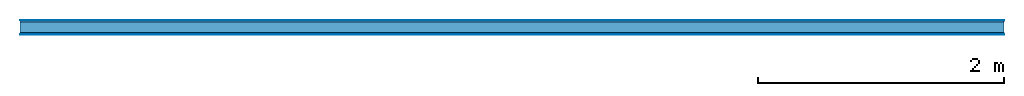
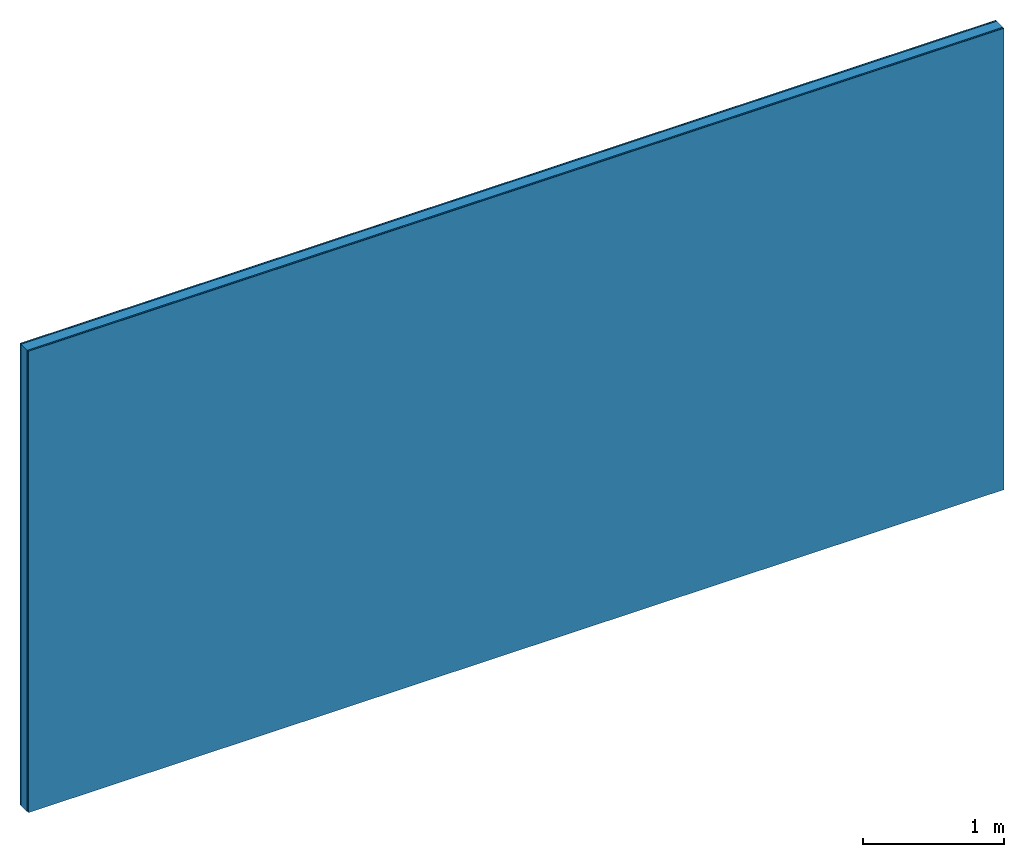
# One storey: 4 plates, 1 member, 1 element without a shape of its own.
"""IFC4 building model written with IfcOpenShell, lengths in metres."""

from ifc_helpers import new_model, si_unit, derived_unit, direction, frame, frame_2d, origin, origin_with_axes, place, context, project, spatial, rectangle, extrude, material, layer, layer_set, type_object, element, aggregate, save


model = new_model("IFC4")

# Units and contexts
plan_context = context("Plan", 3, precision=1e-05, world=origin(), true_north=direction((0.0, 1.0)))
model_context = context("Model", 3, precision=1e-05, world=origin(), true_north=direction((0.0, 1.0)))
ifc_project = project(units=[si_unit("LENGTHUNIT", "METRE"), derived_unit("SOUNDPRESSUREUNIT", [(si_unit("PRESSUREUNIT", "PASCAL", prefix="MICRO"), 0)]), si_unit("ENERGYUNIT", "JOULE", prefix="MEGA"), si_unit("MASSUNIT", "GRAM", prefix="KILO"), derived_unit("THERMALTRANSMITTANCEUNIT", [(si_unit("POWERUNIT", "WATT"), 1), (si_unit("AREAUNIT", "SQUARE_METRE"), -1), (si_unit("THERMODYNAMICTEMPERATUREUNIT", "KELVIN"), -1)]), derived_unit("AREADENSITYUNIT", [(si_unit("MASSUNIT", "GRAM", prefix="KILO"), 1), (si_unit("AREAUNIT", "SQUARE_METRE"), -1)]), derived_unit("USERDEFINED", [(si_unit("ENERGYUNIT", "JOULE", prefix="MEGA"), 1), (si_unit("AREAUNIT", "SQUARE_METRE"), -1)])], contexts=[plan_context, model_context])

# Site, building, storey
site = spatial("IfcSite", under=ifc_project)
building_placement = place(None, origin())
building = spatial("IfcBuilding", under=site, at=building_placement)
storey_placement = place(building_placement, origin())
storey = spatial("IfcBuildingStorey", under=building, at=storey_placement)

# Wall, member, plates
ifc_material_1 = material(Category="04.001")
ifc_layer_1 = layer(ifc_material_1, 0.003, Name="Surface")
ifc_material_2 = material(Name="Plasterboard type A", Category="03.008")
ifc_layer_2 = layer(ifc_material_2, 0.0125, Name="1st layer")
ifc_material_3 = material(Name="of the art")
ifc_layer_3 = layer(ifc_material_3, 0.0, Name="Bond")
ifc_layer_4 = layer(None, 0.087, Name="Support")
ifc_layer_5 = layer(ifc_material_3, 0.0, Name="Bond")
ifc_layer_6 = layer(ifc_material_2, 0.0125, Name="1st layer")
ifc_layer_7 = layer(ifc_material_1, 0.003, Name="Surface")
ifc_layer_set = layer_set([ifc_layer_1, ifc_layer_2, ifc_layer_3, ifc_layer_4, ifc_layer_5, ifc_layer_6, ifc_layer_7])
wall_type = type_object("IfcWallType", Name="C0359", PredefinedType="NOTDEFINED", material=ifc_layer_set)
wall_placement = place(None, frame((0.0, 0.0, 0.0), z_axis=(0.0, -1.0, 0.0), x_axis=(1.0, 0.0, 0.0)))
wall = element("IfcWall", 1, at=wall_placement, inside=storey, type_object=wall_type, material=ifc_layer_set, Name="Wall #1")
ifc_material_4 = material(Name="Solid timber panel")
member_placement = place(wall_placement, origin())
member = element("IfcMember", 2, at=member_placement, material=ifc_material_4, Name="Support", context=plan_context, shape_type="SweptSolid", body=[
    extrude(rectangle(XDim=1.0, YDim=0.087, at=frame_2d((0.5, 0.0435), x_axis=(1.0, 0.0))), frame((0.0, 4.0, 0.0155), z_axis=(0.0, -1.0, 0.0), x_axis=(1.0, 0.0, 0.0)), (0.0, 0.0, 1.0), 4.0),
    extrude(rectangle(XDim=1.0, YDim=0.087, at=frame_2d((0.5, 0.0435), x_axis=(1.0, 0.0))), frame((1.0, 4.0, 0.0155), z_axis=(0.0, -1.0, 0.0), x_axis=(1.0, 0.0, 0.0)), (0.0, 0.0, 1.0), 4.0),
    extrude(rectangle(XDim=1.0, YDim=0.087, at=frame_2d((0.5, 0.0435), x_axis=(1.0, 0.0))), frame((2.0, 4.0, 0.0155), z_axis=(0.0, -1.0, 0.0), x_axis=(1.0, 0.0, 0.0)), (0.0, 0.0, 1.0), 4.0),
    extrude(rectangle(XDim=1.0, YDim=0.087, at=frame_2d((0.5, 0.0435), x_axis=(1.0, 0.0))), frame((3.0, 4.0, 0.0155), z_axis=(0.0, -1.0, 0.0), x_axis=(1.0, 0.0, 0.0)), (0.0, 0.0, 1.0), 4.0),
    extrude(rectangle(XDim=1.0, YDim=0.087, at=frame_2d((0.5, 0.0435), x_axis=(1.0, 0.0))), frame((4.0, 4.0, 0.0155), z_axis=(0.0, -1.0, 0.0), x_axis=(1.0, 0.0, 0.0)), (0.0, 0.0, 1.0), 4.0),
    extrude(rectangle(XDim=1.0, YDim=0.087, at=frame_2d((0.5, 0.0435), x_axis=(1.0, 0.0))), frame((5.0, 4.0, 0.0155), z_axis=(0.0, -1.0, 0.0), x_axis=(1.0, 0.0, 0.0)), (0.0, 0.0, 1.0), 4.0),
    extrude(rectangle(XDim=1.0, YDim=0.087, at=frame_2d((0.5, 0.0435), x_axis=(1.0, 0.0))), frame((6.0, 4.0, 0.0155), z_axis=(0.0, -1.0, 0.0), x_axis=(1.0, 0.0, 0.0)), (0.0, 0.0, 1.0), 4.0),
    extrude(rectangle(XDim=1.0, YDim=0.087, at=frame_2d((0.5, 0.0435), x_axis=(1.0, 0.0))), frame((7.0, 4.0, 0.0155), z_axis=(0.0, -1.0, 0.0), x_axis=(1.0, 0.0, 0.0)), (0.0, 0.0, 1.0), 4.0),
])
plate_1_placement = place(wall_placement, origin())
plate_1 = element("IfcPlate", 3, at=plate_1_placement, material=ifc_material_1, Name="Surface", context=plan_context, shape_type="SweptSolid", body=[
    extrude(rectangle(XDim=8.0, YDim=4.0, at=frame_2d((4.0, 2.0), x_axis=(1.0, 0.0))), origin_with_axes(), (0.0, 0.0, 1.0), 0.003),
])
plate_2_placement = place(wall_placement, origin())
plate_2 = element("IfcPlate", 4, at=plate_2_placement, material=ifc_material_2, Name="1st layer", context=plan_context, shape_type="SweptSolid", body=[
    extrude(rectangle(XDim=8.0, YDim=4.0, at=frame_2d((4.0, 2.0), x_axis=(1.0, 0.0))), frame((0.0, 0.0, 0.003), z_axis=(0.0, 0.0, 1.0), x_axis=(1.0, 0.0, 0.0)), (0.0, 0.0, 1.0), 0.0125),
])
plate_3_placement = place(wall_placement, origin())
plate_3 = element("IfcPlate", 5, at=plate_3_placement, material=ifc_material_2, Name="1st layer", context=plan_context, shape_type="SweptSolid", body=[
    extrude(rectangle(XDim=8.0, YDim=4.0, at=frame_2d((4.0, 2.0), x_axis=(1.0, 0.0))), frame((0.0, 0.0, 0.1025), z_axis=(0.0, 0.0, 1.0), x_axis=(1.0, 0.0, 0.0)), (0.0, 0.0, 1.0), 0.0125),
])
plate_4_placement = place(wall_placement, origin())
plate_4 = element("IfcPlate", 6, at=plate_4_placement, material=ifc_material_1, Name="Surface", context=plan_context, shape_type="SweptSolid", body=[
    extrude(rectangle(XDim=8.0, YDim=4.0, at=frame_2d((4.0, 2.0), x_axis=(1.0, 0.0))), frame((0.0, 0.0, 0.115), z_axis=(0.0, 0.0, 1.0), x_axis=(1.0, 0.0, 0.0)), (0.0, 0.0, 1.0), 0.003),
])
aggregate(wall, [plate_1, plate_2, member, plate_3, plate_4])

save(model, "model.ifc")
